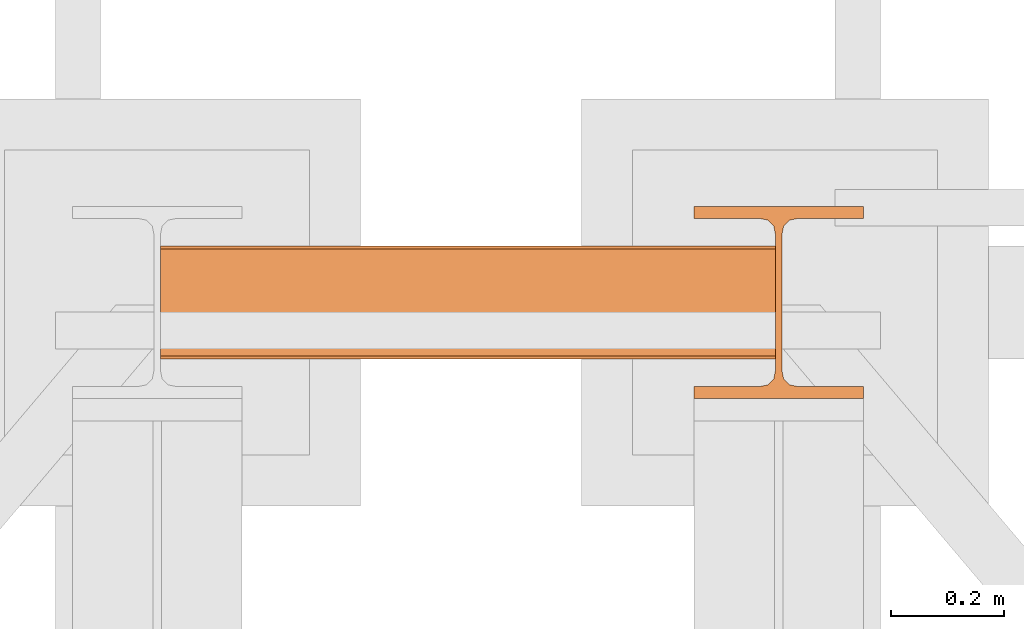
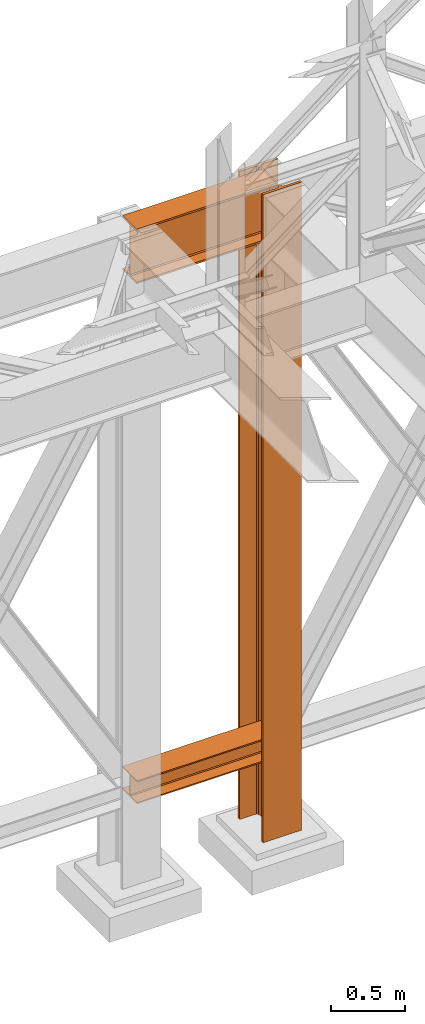
# One storey, part 194 of 208: 3 proxies.
"""IFC2X3 building model written with IfcOpenShell, lengths in millimetres."""

from ifc_helpers import new_model, entity, si_unit, converted_unit, frame, origin, origin_with_axes, place, context, subcontext, project, spatial, faceted_brep, material, element, save


model = new_model("IFC2X3")

# Units and contexts
model_context = context("Model", 3, precision=1e-05, world=origin())
plan_context = context("Plan", 3, precision=1e-05, world=origin())
body_context = subcontext(model_context, "Body", "Model", "MODEL_VIEW")
ifc_project = project(units=[si_unit("LENGTHUNIT", "METRE", prefix="MILLI"), converted_unit("PLANEANGLEUNIT", "DEGREE", entity("IfcPlaneAngleMeasure", 0.0174532925199433), si_unit("PLANEANGLEUNIT", "RADIAN"), dimensions=[0, 0, 0, 0, 0, 0, 0]), si_unit("AREAUNIT", "SQUARE_METRE"), si_unit("VOLUMEUNIT", "CUBIC_METRE")], contexts=[model_context, plan_context])

# Building, storey
building_placement = place(None, origin())
building = spatial("IfcBuilding", under=ifc_project, at=building_placement, CompositionType="COMPLEX")
storey_placement = place(building_placement, origin_with_axes())
storey = spatial("IfcBuildingStorey", under=building, at=storey_placement, Name="Geschoss", CompositionType="ELEMENT")

# Proxies
proxy_1_placement = place(storey_placement, frame((5499.254968580821, -12562.57439501764, 544.9900024165573), z_axis=(0.0, 0.0, 1.0), x_axis=(1.0, 0.0, 0.0)))
element("IfcBuildingElementProxy", 1, at=proxy_1_placement, inside=storey, context=body_context, shape_type="Brep", body=[
    faceted_brep([(1088.009999895692, 0.01000000000021828, 190.0100125169755), (1088.009999895692, 200.0100029802325, 190.0100125169755), (1088.009999895692, 200.0100029802325, 180.0100146031381), (1088.009999895692, 121.2600035762789, 180.0100071525575), (1088.009999895692, 111.9441915473344, 178.1454621052743), (1088.009999895692, 105.1245498640838, 171.3258190250398), (1088.009999895692, 103.2600015571716, 162.0100079274179), (1088.009999895692, 103.2600015571716, 28.00999713897716), (1088.009999895692, 105.1245498640838, 18.69418604135524), (1088.009999895692, 111.9441915473344, 11.87454296112071), (1088.009999895692, 121.2600035762789, 10.00999791383754), (1088.009999895692, 200.0100029802325, 10.00999791383754), (1088.009999895692, 200.0100029802325, 0.01000000000010459), (1088.009999895692, 0.01000000000021828, 0.01000000000010459), (1088.009999895692, 0.01000000000021828, 10.00999791383754), (1088.009999895692, 78.75999940395377, 10.00999791383754), (1088.009999895692, 88.07581143289826, 11.87454296112071), (1088.009999895692, 94.89545311614893, 18.69418604135524), (1088.009999895692, 96.76000142306111, 28.00999713897716), (1088.009999895692, 96.76000142306111, 162.0100079274179), (1088.009999895692, 94.89545311614893, 171.3258190250398), (1088.009999895692, 88.07581143289826, 178.1454621052743), (1088.009999895692, 78.75999940395377, 180.0100071525575), (1088.009999895692, 0.01000000000021828, 180.0100146031381), (1088.009999895692, 200.0100029802325, 190.0100125169755), (1088.009999895692, 0.01000000000021828, 190.0100125169755), (0.01000000000021828, 0.01000000000021828, 190.0100125169754), (0.01000000000021828, 200.0100029802325, 190.0100125169754), (1088.009999895692, 200.0100029802325, 180.0100146031381), (1088.009999895692, 200.0100029802325, 190.0100125169755), (0.01000000000021828, 200.0100029802325, 190.0100125169754), (0.01000000000021828, 200.0100029802325, 180.010014603138), (1088.009999895692, 121.2600035762789, 180.0100071525575), (1088.009999895692, 200.0100029802325, 180.0100146031381), (0.01000000000021828, 200.0100029802325, 180.010014603138), (0.01000000000021828, 121.2600035762789, 180.0100071525574), (1088.009999895692, 111.9441915473344, 178.1454621052743), (1088.009999895692, 121.2600035762789, 180.0100071525575), (0.01000000000021828, 121.2600035762789, 180.0100071525574), (0.01000000000021828, 111.9441915473344, 178.1454621052742), (1088.009999895692, 105.1245498640838, 171.3258190250398), (1088.009999895692, 111.9441915473344, 178.1454621052743), (0.01000000000021828, 111.9441915473344, 178.1454621052742), (0.01000000000021828, 105.1245498640838, 171.3258190250397), (1088.009999895692, 103.2600015571716, 162.0100079274179), (1088.009999895692, 105.1245498640838, 171.3258190250398), (0.01000000000021828, 105.1245498640838, 171.3258190250397), (0.01000000000021828, 103.2600015571716, 162.0100079274178), (1088.009999895692, 103.2600015571716, 28.00999713897716), (1088.009999895692, 103.2600015571716, 162.0100079274179), (0.01000000000021828, 103.2600015571716, 162.0100079274178), (0.01000000000021828, 103.2600015571716, 28.00999713897704), (1088.009999895692, 105.1245498640838, 18.69418604135524), (1088.009999895692, 103.2600015571716, 28.00999713897716), (0.01000000000021828, 103.2600015571716, 28.00999713897704), (0.01000000000021828, 105.1245498640838, 18.69418604135512), (1088.009999895692, 111.9441915473344, 11.87454296112071), (1088.009999895692, 105.1245498640838, 18.69418604135524), (0.01000000000021828, 105.1245498640838, 18.69418604135512), (0.01000000000021828, 111.9441915473344, 11.8745429611206), (1088.009999895692, 121.2600035762789, 10.00999791383754), (1088.009999895692, 111.9441915473344, 11.87454296112071), (0.01000000000021828, 111.9441915473344, 11.8745429611206), (0.01000000000021828, 121.2600035762789, 10.00999791383742), (1088.009999895692, 200.0100029802325, 10.00999791383754), (1088.009999895692, 121.2600035762789, 10.00999791383754), (0.01000000000021828, 121.2600035762789, 10.00999791383742), (0.01000000000021828, 200.0100029802325, 10.00999791383742), (1088.009999895692, 200.0100029802325, 0.01000000000010459), (1088.009999895692, 200.0100029802325, 10.00999791383754), (0.01000000000021828, 200.0100029802325, 10.00999791383742), (0.01000000000021828, 200.0100029802325, 0.009999999999990905), (1088.009999895692, 0.01000000000021828, 0.01000000000010459), (1088.009999895692, 200.0100029802325, 0.01000000000010459), (0.01000000000021828, 200.0100029802325, 0.009999999999990905), (0.01000000000021828, 0.01000000000021828, 0.009999999999990905), (1088.009999895692, 0.01000000000021828, 10.00999791383754), (1088.009999895692, 0.01000000000021828, 0.01000000000010459), (0.01000000000021828, 0.01000000000021828, 0.009999999999990905), (0.01000000000021828, 0.01000000000021828, 10.00999791383742), (1088.009999895692, 78.75999940395377, 10.00999791383754), (1088.009999895692, 0.01000000000021828, 10.00999791383754), (0.01000000000021828, 0.01000000000021828, 10.00999791383742), (0.01000000000021828, 78.75999940395377, 10.00999791383742), (1088.009999895692, 88.07581143289826, 11.87454296112071), (1088.009999895692, 78.75999940395377, 10.00999791383754), (0.01000000000021828, 78.75999940395377, 10.00999791383742), (0.01000000000021828, 88.07581143289826, 11.8745429611206), (1088.009999895692, 94.89545311614893, 18.69418604135524), (1088.009999895692, 88.07581143289826, 11.87454296112071), (0.01000000000021828, 88.07581143289826, 11.8745429611206), (0.01000000000021828, 94.89545311614893, 18.69418604135512), (1088.009999895692, 96.76000142306111, 28.00999713897716), (1088.009999895692, 94.89545311614893, 18.69418604135524), (0.01000000000021828, 94.89545311614893, 18.69418604135512), (0.01000000000021828, 96.76000142306111, 28.00999713897704), (1088.009999895692, 96.76000142306111, 162.0100079274179), (1088.009999895692, 96.76000142306111, 28.00999713897716), (0.01000000000021828, 96.76000142306111, 28.00999713897704), (0.01000000000021828, 96.76000142306111, 162.0100079274178), (1088.009999895692, 94.89545311614893, 171.3258190250398), (1088.009999895692, 96.76000142306111, 162.0100079274179), (0.01000000000021828, 96.76000142306111, 162.0100079274178), (0.01000000000021828, 94.89545311614893, 171.3258190250397), (1088.009999895692, 88.07581143289826, 178.1454621052743), (1088.009999895692, 94.89545311614893, 171.3258190250398), (0.01000000000021828, 94.89545311614893, 171.3258190250397), (0.01000000000021828, 88.07581143289826, 178.1454621052742), (1088.009999895692, 78.75999940395377, 180.0100071525575), (1088.009999895692, 88.07581143289826, 178.1454621052743), (0.01000000000021828, 88.07581143289826, 178.1454621052742), (0.01000000000021828, 78.75999940395377, 180.0100071525574), (1088.009999895692, 0.01000000000021828, 180.0100146031381), (1088.009999895692, 78.75999940395377, 180.0100071525575), (0.01000000000021828, 78.75999940395377, 180.0100071525574), (0.01000000000021828, 0.01000000000021828, 180.010014603138), (1088.009999895692, 0.01000000000021828, 190.0100125169755), (1088.009999895692, 0.01000000000021828, 180.0100146031381), (0.01000000000021828, 0.01000000000021828, 180.010014603138), (0.01000000000021828, 0.01000000000021828, 190.0100125169754), (0.01000000000021828, 0.01000000000021828, 190.0100125169754), (0.01000000000021828, 0.01000000000021828, 180.010014603138), (0.01000000000021828, 78.75999940395377, 180.0100071525574), (0.01000000000021828, 88.07581143289826, 178.1454621052742), (0.01000000000021828, 94.89545311614893, 171.3258190250397), (0.01000000000021828, 96.76000142306111, 162.0100079274178), (0.01000000000021828, 96.76000142306111, 28.00999713897704), (0.01000000000021828, 94.89545311614893, 18.69418604135512), (0.01000000000021828, 88.07581143289826, 11.8745429611206), (0.01000000000021828, 78.75999940395377, 10.00999791383742), (0.01000000000021828, 0.01000000000021828, 10.00999791383742), (0.01000000000021828, 0.01000000000021828, 0.009999999999990905), (0.01000000000021828, 200.0100029802325, 0.009999999999990905), (0.01000000000021828, 200.0100029802325, 10.00999791383742), (0.01000000000021828, 121.2600035762789, 10.00999791383742), (0.01000000000021828, 111.9441915473344, 11.8745429611206), (0.01000000000021828, 105.1245498640838, 18.69418604135512), (0.01000000000021828, 103.2600015571716, 28.00999713897704), (0.01000000000021828, 103.2600015571716, 162.0100079274178), (0.01000000000021828, 105.1245498640838, 171.3258190250397), (0.01000000000021828, 111.9441915473344, 178.1454621052742), (0.01000000000021828, 121.2600035762789, 180.0100071525574), (0.01000000000021828, 200.0100029802325, 180.010014603138), (0.01000000000021828, 200.0100029802325, 190.0100125169754)], [[[0, 1, 2, 3, 4, 5, 6, 7, 8, 9, 10, 11, 12, 13, 14, 15, 16, 17, 18, 19, 20, 21, 22, 23]], [[24, 25, 26, 27]], [[28, 29, 30, 31]], [[32, 33, 34, 35]], [[36, 37, 38, 39]], [[40, 41, 42, 43]], [[44, 45, 46, 47]], [[48, 49, 50, 51]], [[52, 53, 54, 55]], [[56, 57, 58, 59]], [[60, 61, 62, 63]], [[64, 65, 66, 67]], [[68, 69, 70, 71]], [[72, 73, 74, 75]], [[76, 77, 78, 79]], [[80, 81, 82, 83]], [[84, 85, 86, 87]], [[88, 89, 90, 91]], [[92, 93, 94, 95]], [[96, 97, 98, 99]], [[100, 101, 102, 103]], [[104, 105, 106, 107]], [[108, 109, 110, 111]], [[112, 113, 114, 115]], [[116, 117, 118, 119]], [[120, 121, 122, 123, 124, 125, 126, 127, 128, 129, 130, 131, 132, 133, 134, 135, 136, 137, 138, 139, 140, 141, 142, 143]]], orient=[[False], [False], [False], [False], [False], [False], [False], [False], [False], [False], [False], [False], [False], [False], [False], [False], [False], [False], [False], [False], [False], [False], [False], [False], [False], [False]]),
])
proxy_2_placement = place(storey_placement, frame((5499.254968580828, -12557.57439978601, 4834.989987483023), z_axis=(0.0, 0.0, 1.0), x_axis=(1.0, 0.0, 0.0)))
element("IfcBuildingElementProxy", 2, at=proxy_2_placement, inside=storey, context=body_context, shape_type="Brep", body=[
    faceted_brep([(1088.009999895696, 0.01000000000021828, 450.0100178813937), (1088.009999895696, 190.0100125169756, 450.0100178813937), (1088.009999895696, 190.0100125169756, 435.4100240564349), (1088.009999895696, 120.7100073045494, 435.4100091552737), (1088.009999895696, 109.841562265754, 433.2347078418734), (1088.009999895696, 101.8853126263621, 425.2784563398363), (1088.009999895696, 99.71000619068764, 414.4100113010409), (1088.009999895696, 99.71000619068764, 35.60999167919181), (1088.009999895696, 101.8853126263621, 24.74154664039634), (1088.009999895696, 109.841562265754, 16.78529513835929), (1088.009999895696, 120.7100073045494, 14.60999382495902), (1088.009999895696, 190.0100125169756, 14.60999382495902), (1088.009999895696, 190.0100125169756, 0.01000000000021828), (1088.009999895696, 0.01000000000021828, 0.01000000000021828), (1088.009999895696, 0.01000000000021828, 14.60999382495902), (1088.009999895696, 69.3100052124264, 14.60999382495902), (1088.009999895696, 80.17845025122188, 16.78529513835929), (1088.009999895696, 88.13469989061377, 24.74154664039634), (1088.009999895696, 90.3100063262882, 35.60999167919181), (1088.009999895696, 90.3100063262882, 414.4100113010409), (1088.009999895696, 88.13469989061377, 425.2784563398363), (1088.009999895696, 80.17845025122188, 433.2347078418734), (1088.009999895696, 69.3100052124264, 435.4100091552737), (1088.009999895696, 0.01000000000021828, 435.4100240564349), (1088.009999895696, 190.0100125169756, 450.0100178813937), (1088.009999895696, 0.01000000000021828, 450.0100178813937), (0.01000000000021828, 0.01000000000021828, 450.0100178813937), (0.01000000000021828, 190.0100125169756, 450.0100178813937), (1088.009999895696, 190.0100125169756, 435.4100240564349), (1088.009999895696, 190.0100125169756, 450.0100178813937), (0.01000000000021828, 190.0100125169756, 450.0100178813937), (0.01000000000021828, 190.0100125169756, 435.4100240564349), (1088.009999895696, 120.7100073045494, 435.4100091552737), (1088.009999895696, 190.0100125169756, 435.4100240564349), (0.01000000000021828, 190.0100125169756, 435.4100240564349), (0.01000000000021828, 120.7100073045494, 435.4100091552737), (1088.009999895696, 109.841562265754, 433.2347078418734), (1088.009999895696, 120.7100073045494, 435.4100091552737), (0.01000000000021828, 120.7100073045494, 435.4100091552737), (0.01000000000021828, 109.841562265754, 433.2347078418734), (1088.009999895696, 101.8853126263621, 425.2784563398363), (1088.009999895696, 109.841562265754, 433.2347078418734), (0.01000000000021828, 109.841562265754, 433.2347078418734), (0.01000000000021828, 101.8853126263621, 425.2784563398363), (1088.009999895696, 99.71000619068764, 414.4100113010409), (1088.009999895696, 101.8853126263621, 425.2784563398363), (0.01000000000021828, 101.8853126263621, 425.2784563398363), (0.01000000000021828, 99.71000619068764, 414.4100113010409), (1088.009999895696, 99.71000619068764, 35.60999167919181), (1088.009999895696, 99.71000619068764, 414.4100113010409), (0.01000000000021828, 99.71000619068764, 414.4100113010409), (0.01000000000021828, 99.71000619068764, 35.60999167919181), (1088.009999895696, 101.8853126263621, 24.74154664039634), (1088.009999895696, 99.71000619068764, 35.60999167919181), (0.01000000000021828, 99.71000619068764, 35.60999167919181), (0.01000000000021828, 101.8853126263621, 24.74154664039634), (1088.009999895696, 109.841562265754, 16.78529513835929), (1088.009999895696, 101.8853126263621, 24.74154664039634), (0.01000000000021828, 101.8853126263621, 24.74154664039634), (0.01000000000021828, 109.841562265754, 16.78529513835929), (1088.009999895696, 120.7100073045494, 14.60999382495902), (1088.009999895696, 109.841562265754, 16.78529513835929), (0.01000000000021828, 109.841562265754, 16.78529513835929), (0.01000000000021828, 120.7100073045494, 14.60999382495902), (1088.009999895696, 190.0100125169756, 14.60999382495902), (1088.009999895696, 120.7100073045494, 14.60999382495902), (0.01000000000021828, 120.7100073045494, 14.60999382495902), (0.01000000000021828, 190.0100125169756, 14.60999382495902), (1088.009999895696, 190.0100125169756, 0.01000000000021828), (1088.009999895696, 190.0100125169756, 14.60999382495902), (0.01000000000021828, 190.0100125169756, 14.60999382495902), (0.01000000000021828, 190.0100125169756, 0.01000000000021828), (1088.009999895696, 0.01000000000021828, 0.01000000000021828), (1088.009999895696, 190.0100125169756, 0.01000000000021828), (0.01000000000021828, 190.0100125169756, 0.01000000000021828), (0.01000000000021828, 0.01000000000021828, 0.01000000000021828), (1088.009999895696, 0.01000000000021828, 14.60999382495902), (1088.009999895696, 0.01000000000021828, 0.01000000000021828), (0.01000000000021828, 0.01000000000021828, 0.01000000000021828), (0.01000000000021828, 0.01000000000021828, 14.60999382495902), (1088.009999895696, 69.3100052124264, 14.60999382495902), (1088.009999895696, 0.01000000000021828, 14.60999382495902), (0.01000000000021828, 0.01000000000021828, 14.60999382495902), (0.01000000000021828, 69.3100052124264, 14.60999382495902), (1088.009999895696, 80.17845025122188, 16.78529513835929), (1088.009999895696, 69.3100052124264, 14.60999382495902), (0.01000000000021828, 69.3100052124264, 14.60999382495902), (0.01000000000021828, 80.17845025122188, 16.78529513835929), (1088.009999895696, 88.13469989061377, 24.74154664039634), (1088.009999895696, 80.17845025122188, 16.78529513835929), (0.01000000000021828, 80.17845025122188, 16.78529513835929), (0.01000000000021828, 88.13469989061377, 24.74154664039634), (1088.009999895696, 90.3100063262882, 35.60999167919181), (1088.009999895696, 88.13469989061377, 24.74154664039634), (0.01000000000021828, 88.13469989061377, 24.74154664039634), (0.01000000000021828, 90.3100063262882, 35.60999167919181), (1088.009999895696, 90.3100063262882, 414.4100113010409), (1088.009999895696, 90.3100063262882, 35.60999167919181), (0.01000000000021828, 90.3100063262882, 35.60999167919181), (0.01000000000021828, 90.3100063262882, 414.4100113010409), (1088.009999895696, 88.13469989061377, 425.2784563398363), (1088.009999895696, 90.3100063262882, 414.4100113010409), (0.01000000000021828, 90.3100063262882, 414.4100113010409), (0.01000000000021828, 88.13469989061377, 425.2784563398363), (1088.009999895696, 80.17845025122188, 433.2347078418734), (1088.009999895696, 88.13469989061377, 425.2784563398363), (0.01000000000021828, 88.13469989061377, 425.2784563398363), (0.01000000000021828, 80.17845025122188, 433.2347078418734), (1088.009999895696, 69.3100052124264, 435.4100091552737), (1088.009999895696, 80.17845025122188, 433.2347078418734), (0.01000000000021828, 80.17845025122188, 433.2347078418734), (0.01000000000021828, 69.3100052124264, 435.4100091552737), (1088.009999895696, 0.01000000000021828, 435.4100240564349), (1088.009999895696, 69.3100052124264, 435.4100091552737), (0.01000000000021828, 69.3100052124264, 435.4100091552737), (0.01000000000021828, 0.01000000000021828, 435.4100240564349), (1088.009999895696, 0.01000000000021828, 450.0100178813937), (1088.009999895696, 0.01000000000021828, 435.4100240564349), (0.01000000000021828, 0.01000000000021828, 435.4100240564349), (0.01000000000021828, 0.01000000000021828, 450.0100178813937), (0.01000000000021828, 0.01000000000021828, 450.0100178813937), (0.01000000000021828, 0.01000000000021828, 435.4100240564349), (0.01000000000021828, 69.3100052124264, 435.4100091552737), (0.01000000000021828, 80.17845025122188, 433.2347078418734), (0.01000000000021828, 88.13469989061377, 425.2784563398363), (0.01000000000021828, 90.3100063262882, 414.4100113010409), (0.01000000000021828, 90.3100063262882, 35.60999167919181), (0.01000000000021828, 88.13469989061377, 24.74154664039634), (0.01000000000021828, 80.17845025122188, 16.78529513835929), (0.01000000000021828, 69.3100052124264, 14.60999382495902), (0.01000000000021828, 0.01000000000021828, 14.60999382495902), (0.01000000000021828, 0.01000000000021828, 0.01000000000021828), (0.01000000000021828, 190.0100125169756, 0.01000000000021828), (0.01000000000021828, 190.0100125169756, 14.60999382495902), (0.01000000000021828, 120.7100073045494, 14.60999382495902), (0.01000000000021828, 109.841562265754, 16.78529513835929), (0.01000000000021828, 101.8853126263621, 24.74154664039634), (0.01000000000021828, 99.71000619068764, 35.60999167919181), (0.01000000000021828, 99.71000619068764, 414.4100113010409), (0.01000000000021828, 101.8853126263621, 425.2784563398363), (0.01000000000021828, 109.841562265754, 433.2347078418734), (0.01000000000021828, 120.7100073045494, 435.4100091552737), (0.01000000000021828, 190.0100125169756, 435.4100240564349), (0.01000000000021828, 190.0100125169756, 450.0100178813937)], [[[0, 1, 2, 3, 4, 5, 6, 7, 8, 9, 10, 11, 12, 13, 14, 15, 16, 17, 18, 19, 20, 21, 22, 23]], [[24, 25, 26, 27]], [[28, 29, 30, 31]], [[32, 33, 34, 35]], [[36, 37, 38, 39]], [[40, 41, 42, 43]], [[44, 45, 46, 47]], [[48, 49, 50, 51]], [[52, 53, 54, 55]], [[56, 57, 58, 59]], [[60, 61, 62, 63]], [[64, 65, 66, 67]], [[68, 69, 70, 71]], [[72, 73, 74, 75]], [[76, 77, 78, 79]], [[80, 81, 82, 83]], [[84, 85, 86, 87]], [[88, 89, 90, 91]], [[92, 93, 94, 95]], [[96, 97, 98, 99]], [[100, 101, 102, 103]], [[104, 105, 106, 107]], [[108, 109, 110, 111]], [[112, 113, 114, 115]], [[116, 117, 118, 119]], [[120, 121, 122, 123, 124, 125, 126, 127, 128, 129, 130, 131, 132, 133, 134, 135, 136, 137, 138, 139, 140, 141, 142, 143]]], orient=[[False], [False], [False], [False], [False], [False], [False], [False], [False], [False], [False], [False], [False], [False], [False], [False], [False], [False], [False], [False], [False], [False], [False], [False], [False], [False]]),
])
ifc_material = material(Name="35/80cm")
proxy_3_placement = place(storey_placement, frame((6443.254962568202, -12632.57439531566, -65.01000000000022), z_axis=(0.0, 0.0, 1.0), x_axis=(1.0, 0.0, 0.0)))
element("IfcBuildingElementProxy", 3, at=proxy_3_placement, inside=storey, material=ifc_material, context=body_context, shape_type="Brep", body=[
    faceted_brep([(300.0100119209292, 0.01000000000021828, 0.01000000000027512), (300.0100119209292, 21.51000631809256, 0.01000000000027512), (183.0100057816508, 21.51000631809256, 0.01000000000027512), (169.036290997863, 24.30682016372703, 0.01000000000027512), (158.8068282401564, 34.53628850936912, 0.01000000000027512), (156.0100060126188, 48.51000143051169, 0.01000000000027512), (156.0100060126188, 291.5099946951868, 0.01000000000027512), (158.8068282401564, 305.48371506691, 0.01000000000027512), (169.036290997863, 315.7131685113909, 0.01000000000027512), (183.0100057816508, 318.5099972581866, 0.01000000000027512), (300.0100119209292, 318.5099972581866, 0.01000000000027512), (300.0100119209292, 340.0100035762789, 0.01000000000027512), (0.01000000000021828, 340.0100035762789, 0.01000000000027512), (0.01000000000021828, 318.5099972581866, 0.01000000000027512), (117.0100061392786, 318.5099972581866, 0.01000000000027512), (130.9837209230664, 315.7131685113909, 0.01000000000027512), (141.213183680773, 305.48371506691, 0.01000000000027512), (144.0100059083106, 291.5099946951868, 0.01000000000027512), (144.0100059083106, 48.51000143051169, 0.01000000000027512), (141.213183680773, 34.53628850936912, 0.01000000000027512), (130.9837209230664, 24.30682016372703, 0.01000000000027512), (117.0100061392786, 21.51000631809256, 0.01000000000027512), (0.01000000000021828, 21.51000631809256, 0.01000000000027512), (0.01000000000021828, 0.01000000000021828, 0.01000000000027512), (300.0100119209292, 21.51000631809256, 5350.010005364416), (300.0100119209292, 0.01000000000021828, 5350.010005364416), (0.01000000000021828, 0.01000000000021828, 5350.010005364416), (0.01000000000021828, 21.51000631809256, 5350.010005364416), (117.0100061392786, 21.51000631809256, 5350.010005364416), (130.9837209230664, 24.30682016372703, 5350.010005364416), (141.213183680773, 34.53628850936912, 5350.010005364416), (144.0100059083106, 48.51000143051169, 5350.010005364416), (144.0100059083106, 291.5099946951868, 5350.010005364416), (141.213183680773, 305.48371506691, 5350.010005364416), (130.9837209230664, 315.7131685113909, 5350.010005364416), (117.0100061392786, 318.5099972581866, 5350.010005364416), (0.01000000000021828, 318.5099972581866, 5350.010005364416), (0.01000000000021828, 340.0100035762789, 5350.010005364416), (300.0100119209292, 340.0100035762789, 5350.010005364416), (300.0100119209292, 318.5099972581866, 5350.010005364416), (183.0100057816508, 318.5099972581866, 5350.010005364416), (169.036290997863, 315.7131685113909, 5350.010005364416), (158.8068282401564, 305.48371506691, 5350.010005364416), (156.0100060126188, 291.5099946951868, 5350.010005364416), (156.0100060126188, 48.51000143051169, 5350.010005364416), (158.8068282401564, 34.53628850936912, 5350.010005364416), (169.036290997863, 24.30682016372703, 5350.010005364416), (183.0100057816508, 21.51000631809256, 5350.010005364416), (300.0100119209292, 21.51000631809256, 0.01000000000027512), (300.0100119209292, 0.01000000000021828, 0.01000000000027512), (300.0100119209292, 0.01000000000021828, 5350.010005364416), (300.0100119209292, 21.51000631809256, 5350.010005364416), (183.0100057816508, 21.51000631809256, 0.01000000000027512), (300.0100119209292, 21.51000631809256, 0.01000000000027512), (300.0100119209292, 21.51000631809256, 5350.010005364416), (183.0100057816508, 21.51000631809256, 5350.010005364416), (169.036290997863, 24.30682016372703, 0.01000000000027512), (183.0100057816508, 21.51000631809256, 0.01000000000027512), (183.0100057816508, 21.51000631809256, 5350.010005364416), (169.036290997863, 24.30682016372703, 5350.010005364416), (158.8068282401564, 34.53628850936912, 0.01000000000027512), (169.036290997863, 24.30682016372703, 0.01000000000027512), (169.036290997863, 24.30682016372703, 5350.010005364416), (158.8068282401564, 34.53628850936912, 5350.010005364416), (156.0100060126188, 48.51000143051169, 0.01000000000027512), (158.8068282401564, 34.53628850936912, 0.01000000000027512), (158.8068282401564, 34.53628850936912, 5350.010005364416), (156.0100060126188, 48.51000143051169, 5350.010005364416), (156.0100060126188, 291.5099946951868, 0.01000000000027512), (156.0100060126188, 48.51000143051169, 0.01000000000027512), (156.0100060126188, 48.51000143051169, 5350.010005364416), (156.0100060126188, 291.5099946951868, 5350.010005364416), (158.8068282401564, 305.48371506691, 0.01000000000027512), (156.0100060126188, 291.5099946951868, 0.01000000000027512), (156.0100060126188, 291.5099946951868, 5350.010005364416), (158.8068282401564, 305.48371506691, 5350.010005364416), (169.036290997863, 315.7131685113909, 0.01000000000027512), (158.8068282401564, 305.48371506691, 0.01000000000027512), (158.8068282401564, 305.48371506691, 5350.010005364416), (169.036290997863, 315.7131685113909, 5350.010005364416), (183.0100057816508, 318.5099972581866, 0.01000000000027512), (169.036290997863, 315.7131685113909, 0.01000000000027512), (169.036290997863, 315.7131685113909, 5350.010005364416), (183.0100057816508, 318.5099972581866, 5350.010005364416), (300.0100119209292, 318.5099972581866, 0.01000000000027512), (183.0100057816508, 318.5099972581866, 0.01000000000027512), (183.0100057816508, 318.5099972581866, 5350.010005364416), (300.0100119209292, 318.5099972581866, 5350.010005364416), (300.0100119209292, 340.0100035762789, 0.01000000000027512), (300.0100119209292, 318.5099972581866, 0.01000000000027512), (300.0100119209292, 318.5099972581866, 5350.010005364416), (300.0100119209292, 340.0100035762789, 5350.010005364416), (0.01000000000021828, 340.0100035762789, 0.01000000000027512), (300.0100119209292, 340.0100035762789, 0.01000000000027512), (300.0100119209292, 340.0100035762789, 5350.010005364416), (0.01000000000021828, 340.0100035762789, 5350.010005364416), (0.01000000000021828, 318.5099972581866, 0.01000000000027512), (0.01000000000021828, 340.0100035762789, 0.01000000000027512), (0.01000000000021828, 340.0100035762789, 5350.010005364416), (0.01000000000021828, 318.5099972581866, 5350.010005364416), (117.0100061392786, 318.5099972581866, 0.01000000000027512), (0.01000000000021828, 318.5099972581866, 0.01000000000027512), (0.01000000000021828, 318.5099972581866, 5350.010005364416), (117.0100061392786, 318.5099972581866, 5350.010005364416), (130.9837209230664, 315.7131685113909, 0.01000000000027512), (117.0100061392786, 318.5099972581866, 0.01000000000027512), (117.0100061392786, 318.5099972581866, 5350.010005364416), (130.9837209230664, 315.7131685113909, 5350.010005364416), (141.213183680773, 305.48371506691, 0.01000000000027512), (130.9837209230664, 315.7131685113909, 0.01000000000027512), (130.9837209230664, 315.7131685113909, 5350.010005364416), (141.213183680773, 305.48371506691, 5350.010005364416), (144.0100059083106, 291.5099946951868, 0.01000000000027512), (141.213183680773, 305.48371506691, 0.01000000000027512), (141.213183680773, 305.48371506691, 5350.010005364416), (144.0100059083106, 291.5099946951868, 5350.010005364416), (144.0100059083106, 48.51000143051169, 0.01000000000027512), (144.0100059083106, 291.5099946951868, 0.01000000000027512), (144.0100059083106, 291.5099946951868, 5350.010005364416), (144.0100059083106, 48.51000143051169, 5350.010005364416), (141.213183680773, 34.53628850936912, 0.01000000000027512), (144.0100059083106, 48.51000143051169, 0.01000000000027512), (144.0100059083106, 48.51000143051169, 5350.010005364416), (141.213183680773, 34.53628850936912, 5350.010005364416), (130.9837209230664, 24.30682016372703, 0.01000000000027512), (141.213183680773, 34.53628850936912, 0.01000000000027512), (141.213183680773, 34.53628850936912, 5350.010005364416), (130.9837209230664, 24.30682016372703, 5350.010005364416), (117.0100061392786, 21.51000631809256, 0.01000000000027512), (130.9837209230664, 24.30682016372703, 0.01000000000027512), (130.9837209230664, 24.30682016372703, 5350.010005364416), (117.0100061392786, 21.51000631809256, 5350.010005364416), (0.01000000000021828, 21.51000631809256, 0.01000000000027512), (117.0100061392786, 21.51000631809256, 0.01000000000027512), (117.0100061392786, 21.51000631809256, 5350.010005364416), (0.01000000000021828, 21.51000631809256, 5350.010005364416), (0.01000000000021828, 0.01000000000021828, 0.01000000000027512), (0.01000000000021828, 21.51000631809256, 0.01000000000027512), (0.01000000000021828, 21.51000631809256, 5350.010005364416), (0.01000000000021828, 0.01000000000021828, 5350.010005364416), (300.0100119209292, 0.01000000000021828, 0.01000000000027512), (0.01000000000021828, 0.01000000000021828, 0.01000000000027512), (0.01000000000021828, 0.01000000000021828, 5350.010005364416), (300.0100119209292, 0.01000000000021828, 5350.010005364416)], [[[0, 1, 2, 3, 4, 5, 6, 7, 8, 9, 10, 11, 12, 13, 14, 15, 16, 17, 18, 19, 20, 21, 22, 23]], [[24, 25, 26, 27, 28, 29, 30, 31, 32, 33, 34, 35, 36, 37, 38, 39, 40, 41, 42, 43, 44, 45, 46, 47]], [[48, 49, 50, 51]], [[52, 53, 54, 55]], [[56, 57, 58, 59]], [[60, 61, 62, 63]], [[64, 65, 66, 67]], [[68, 69, 70, 71]], [[72, 73, 74, 75]], [[76, 77, 78, 79]], [[80, 81, 82, 83]], [[84, 85, 86, 87]], [[88, 89, 90, 91]], [[92, 93, 94, 95]], [[96, 97, 98, 99]], [[100, 101, 102, 103]], [[104, 105, 106, 107]], [[108, 109, 110, 111]], [[112, 113, 114, 115]], [[116, 117, 118, 119]], [[120, 121, 122, 123]], [[124, 125, 126, 127]], [[128, 129, 130, 131]], [[132, 133, 134, 135]], [[136, 137, 138, 139]], [[140, 141, 142, 143]]], orient=[[False], [False], [False], [False], [False], [False], [False], [False], [False], [False], [False], [False], [False], [False], [False], [False], [False], [False], [False], [False], [False], [False], [False], [False], [False], [False]]),
])

save(model, "model.ifc")
